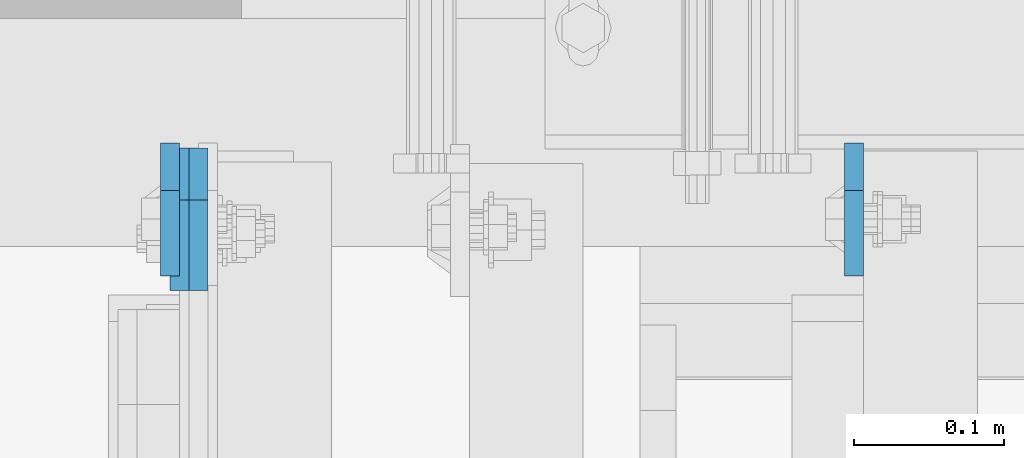
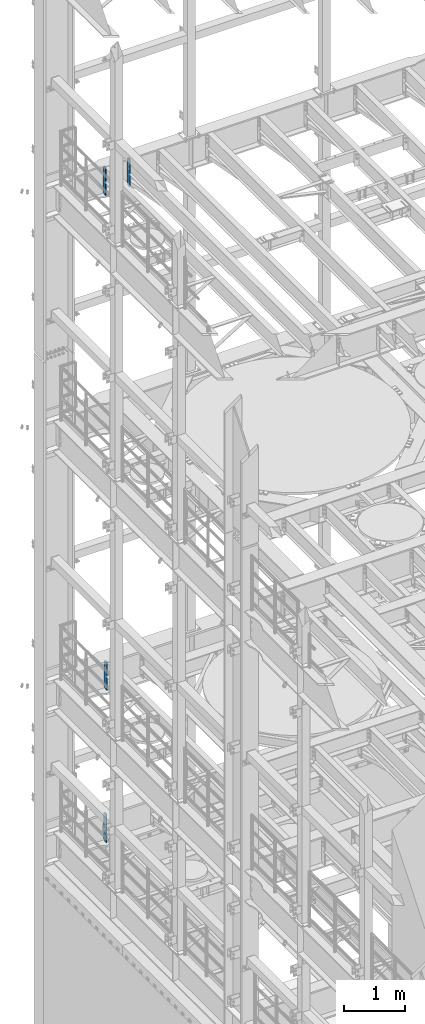
# One storey, part 1775 of 1876: 4 plates, 3 elements without a shape of their own.
"""IFC2X3 building model written with IfcOpenShell, lengths in millimetres."""

from ifc_helpers import new_model, si_unit, frame, origin_with_axes, place, context, subcontext, project, spatial, faceted_brep, material, type_object, element, aggregate, save


model = new_model("IFC2X3")

# Units and contexts
model_context = context("Model", 3, precision=1e-05, world=origin_with_axes())
body_context = subcontext(model_context, "Body", "Model", "MODEL_VIEW")
ifc_project = project(units=[si_unit("LENGTHUNIT", "METRE", prefix="MILLI"), si_unit("AREAUNIT", "SQUARE_METRE"), si_unit("VOLUMEUNIT", "CUBIC_METRE"), si_unit("MASSUNIT", "GRAM", prefix="KILO"), si_unit("TIMEUNIT", "SECOND"), si_unit("PLANEANGLEUNIT", "RADIAN"), si_unit("SOLIDANGLEUNIT", "STERADIAN"), si_unit("THERMODYNAMICTEMPERATUREUNIT", "DEGREE_CELSIUS"), si_unit("LUMINOUSINTENSITYUNIT", "LUMEN")], contexts=[model_context])

# Site, building, storey
site_placement = place(None, origin_with_axes())
site = spatial("IfcSite", under=ifc_project, at=site_placement, CompositionType="ELEMENT")
building_placement = place(site_placement, origin_with_axes())
building = spatial("IfcBuilding", under=site, at=building_placement, Name="Undefined", CompositionType="ELEMENT")
storey_placement = place(building_placement, origin_with_axes())
storey = spatial("IfcBuildingStorey", under=building, at=storey_placement, Name="Undefined", CompositionType="ELEMENT", Elevation=0.0)

# Assembly, plates
assembly_1_placement = place(storey_placement, origin_with_axes())
assembly_1 = element("IfcElementAssembly", 1, at=assembly_1_placement, inside=storey, Name="BEAM", AssemblyPlace="NOTDEFINED", PredefinedType="RIGID_FRAME")
ifc_material = material(Name="STEEL/A36")
plate_type_1 = type_object("IfcPlateType", PredefinedType="NOTDEFINED")
plate_1_placement = place(assembly_1_placement, frame((1374.77499990463, 13708.85625, 17386.3), z_axis=(0.0, 0.0, 1.0), x_axis=(0.0, -1.0, 0.0)))
plate_1 = element("IfcPlate", 2, at=plate_1_placement, type_object=plate_type_1, material=ifc_material, Name="PLATE", context=body_context, shape_type="Brep", body=[
    faceted_brep([(0.0, -6.34999999999991, 31.75), (0.0, -6.34999999999991, 539.75), (0.0, 6.34999999999991, 539.75), (0.0, 6.34999999999991, 31.75), (31.75, -6.34999999999991, 571.5), (31.75, 6.34999999999991, 571.5), (88.9000015258789, -6.34999999999991, 571.5), (88.9000015258789, 6.34999999999991, 571.5), (88.9000015258789, -6.34999999999991, 0.0), (88.9000015258789, 6.34999999999991, 0.0), (31.75, -6.34999999999991, 0.0), (31.75, 6.34999999999991, 0.0)], [[[0, 1, 2, 3]], [[1, 4, 5, 2]], [[4, 6, 7, 5]], [[6, 8, 9, 7]], [[8, 10, 11, 9]], [[10, 0, 3, 11]], [[5, 7, 9, 11, 3, 2]], [[10, 8, 6, 4, 1, 0]]]),
])
plate_2_placement = place(assembly_1_placement, frame((917.574999904632, 13708.85625, 17386.3), z_axis=(0.0, 0.0, 1.0), x_axis=(0.0, -1.0, 0.0)))
plate_2 = element("IfcPlate", 3, at=plate_2_placement, type_object=plate_type_1, material=ifc_material, Name="PLATE", context=body_context, shape_type="Brep", body=[
    faceted_brep([(0.0, -6.34999999999991, 31.75), (0.0, -6.34999999999991, 539.75), (0.0, 6.34999999999991, 539.75), (0.0, 6.34999999999991, 31.75), (31.75, -6.34999999999991, 571.5), (31.75, 6.34999999999991, 571.5), (88.9000015258789, -6.34999999999991, 571.5), (88.9000015258789, 6.34999999999991, 571.5), (88.9000015258789, -6.34999999999991, 0.0), (88.9000015258789, 6.34999999999991, 0.0), (31.75, -6.34999999999991, 0.0), (31.75, 6.34999999999991, 0.0)], [[[0, 1, 2, 3]], [[1, 4, 5, 2]], [[4, 6, 7, 5]], [[6, 8, 9, 7]], [[8, 10, 11, 9]], [[10, 0, 3, 11]], [[5, 7, 9, 11, 3, 2]], [[10, 8, 6, 4, 1, 0]]]),
])
aggregate(assembly_1, [plate_1, plate_2])

# Assembly, plate
assembly_2_placement = place(storey_placement, origin_with_axes())
assembly_2 = element("IfcElementAssembly", 4, at=assembly_2_placement, inside=storey, Name="BEAM", AssemblyPlace="NOTDEFINED", PredefinedType="RIGID_FRAME")
plate_type_2 = type_object("IfcPlateType", PredefinedType="NOTDEFINED")
plate_3_placement = place(assembly_2_placement, frame((936.624999904632, 13705.68125, 7543.8), z_axis=(0.0, 0.0, 1.0), x_axis=(0.0, -1.0, 0.0)))
plate_3 = element("IfcPlate", 5, at=plate_3_placement, type_object=plate_type_2, material=ifc_material, Name="PLATE", context=body_context, shape_type="Brep", body=[
    faceted_brep([(0.0, -6.34999999999991, 34.9249992370605), (0.0, -6.35000000000036, 538.162475585938), (0.0, 6.35000000000036, 538.162475585938), (0.0, 6.34999999999991, 34.9249992370605), (34.9249992370605, -6.34999999999991, 573.087524414062), (34.9249992370605, 6.34999999999991, 573.087524414062), (95.25, -6.34999999999991, 573.087524414062), (95.25, 6.34999999999991, 573.087524414062), (95.25, -6.35000000000036, 0.0), (95.25, 6.35000000000036, 0.0), (34.9249992370605, -6.34999999999991, 0.0), (34.9249992370605, 6.34999999999991, 0.0)], [[[0, 1, 2, 3]], [[1, 4, 5, 2]], [[4, 6, 7, 5]], [[6, 8, 9, 7]], [[8, 10, 11, 9]], [[10, 0, 3, 11]], [[5, 7, 9, 11, 3, 2]], [[10, 8, 6, 4, 1, 0]]]),
])
aggregate(assembly_2, [plate_3])

assembly_3_placement = place(storey_placement, origin_with_axes())
assembly_3 = element("IfcElementAssembly", 6, at=assembly_3_placement, inside=storey, Name="BEAM", AssemblyPlace="NOTDEFINED", PredefinedType="RIGID_FRAME")
plate_4_placement = place(assembly_3_placement, frame((923.924999904632, 13705.68125, 4521.2), z_axis=(0.0, 0.0, 1.0), x_axis=(0.0, -1.0, 0.0)))
plate_4 = element("IfcPlate", 7, at=plate_4_placement, type_object=plate_type_2, material=ifc_material, Name="PLATE", context=body_context, shape_type="Brep", body=[
    faceted_brep([(0.0, -6.34999999999991, 34.9249992370605), (0.0, -6.35000000000036, 538.162475585938), (0.0, 6.35000000000036, 538.162475585938), (0.0, 6.34999999999991, 34.9249992370605), (34.9249992370605, -6.34999999999991, 573.087524414062), (34.9249992370605, 6.34999999999991, 573.087524414062), (95.25, -6.34999999999991, 573.087524414062), (95.25, 6.34999999999991, 573.087524414062), (95.25, -6.35000000000036, 0.0), (95.25, 6.35000000000036, 0.0), (34.9249992370605, -6.34999999999991, 0.0), (34.9249992370605, 6.34999999999991, 0.0)], [[[0, 1, 2, 3]], [[1, 4, 5, 2]], [[4, 6, 7, 5]], [[6, 8, 9, 7]], [[8, 10, 11, 9]], [[10, 0, 3, 11]], [[5, 7, 9, 11, 3, 2]], [[10, 8, 6, 4, 1, 0]]]),
])
aggregate(assembly_3, [plate_4])

save(model, "model.ifc")
